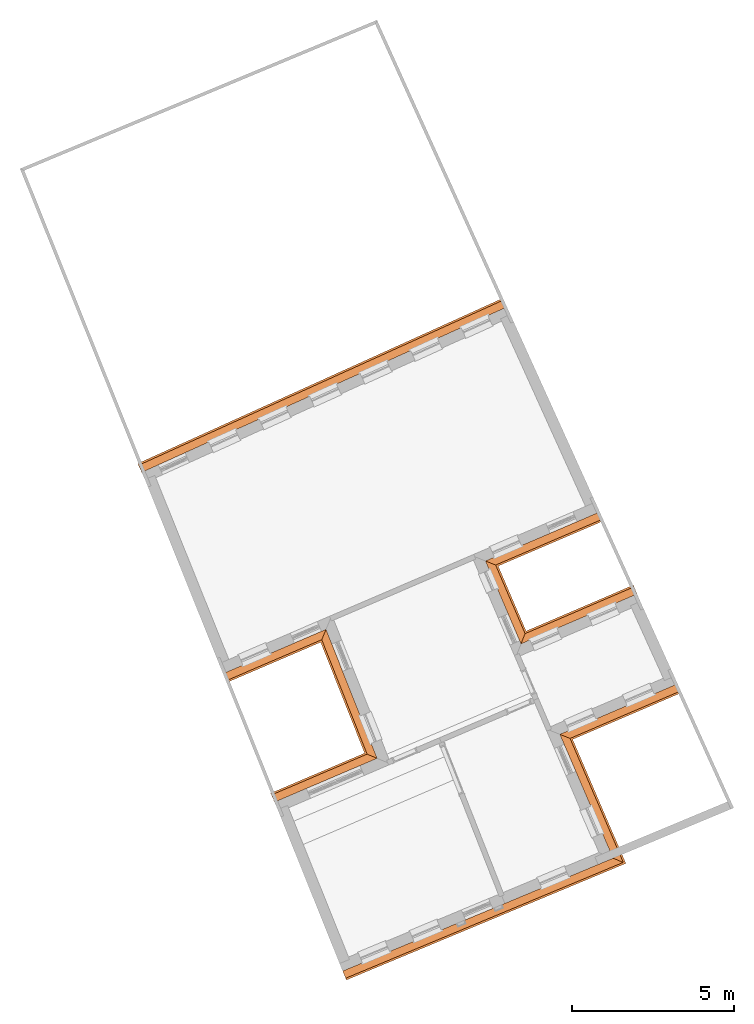
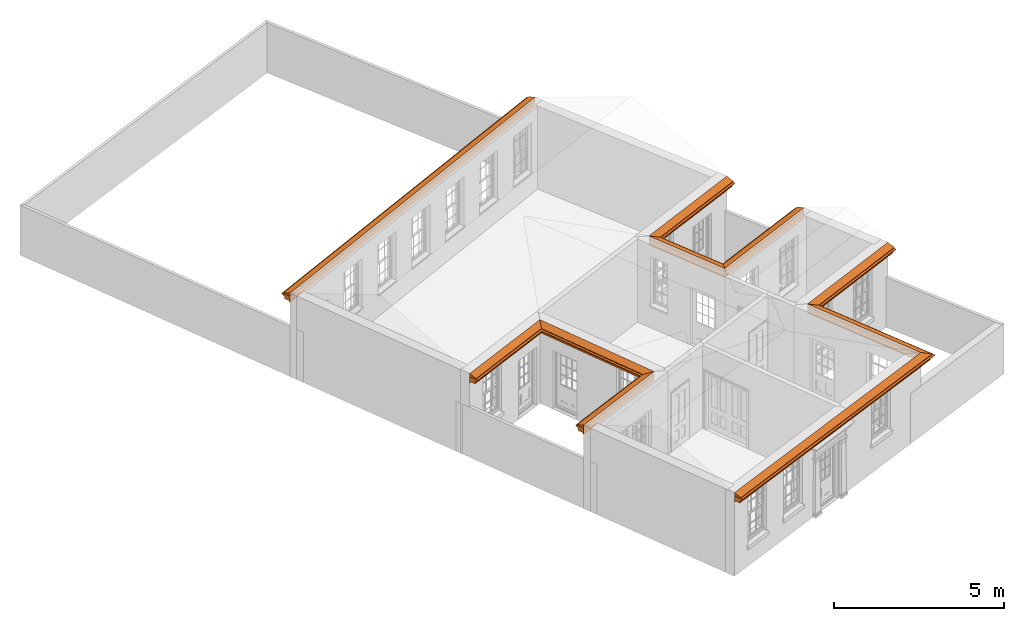
# One storey, part 19 of 19: 8 proxies.
"""IFC2X3 building model written with IfcOpenShell, lengths in metres."""

from ifc_helpers import new_model, entity, si_unit, frame, origin, place, context, subcontext, project, spatial, element, save


model = new_model("IFC2X3")

# Units and contexts
model_context = context("Model", 3, world=origin())
body_context = subcontext(model_context, "Body", "Model", "MODEL_VIEW")
ifc_project = project(units=[si_unit("PLANEANGLEUNIT", "RADIAN"), si_unit("MASSUNIT", "GRAM", prefix="KILO"), si_unit("FORCEUNIT", "NEWTON", prefix="KILO"), si_unit("LENGTHUNIT", "METRE")], contexts=[model_context])

# Site, building, storey
site_placement = place(None, origin())
site = spatial("IfcSite", under=ifc_project, at=site_placement, CompositionType="ELEMENT")
building_placement = place(None, origin())
building = spatial("IfcBuilding", under=site, at=building_placement, Name="Building plot-0", CompositionType="ELEMENT")
storey_placement = place(None, origin())
storey = spatial("IfcBuildingStorey", under=building, at=storey_placement, Name="Floor 0", CompositionType="ELEMENT", Elevation=0.0)

# Proxies
proxy_1_placement = place(storey_placement, frame((0.0, 0.0, 3.0)))
axis2_placement3_d_1 = entity("IfcAxis2Placement3D", entity("IfcCartesianPoint", [0.0, 0.0, 0.0]))
element("IfcBuildingElementProxy", 1, at=proxy_1_placement, inside=storey, Name="eaves", CompositionType="ELEMENT", context=body_context, shape_type="SweptSolid", held_by="IfcProductRepresentation", body=[
    entity("IfcSurfaceCurveSweptAreaSolid", entity("IfcArbitraryClosedProfileDef", "AREA", None, entity("IfcPolyline", [entity("IfcCartesianPoint", [-0.11, 0.25]), entity("IfcCartesianPoint", [-0.33, 0.25]), entity("IfcCartesianPoint", [-0.33, 0.265]), entity("IfcCartesianPoint", [-0.318, 0.268]), entity("IfcCartesianPoint", [-0.309, 0.274]), entity("IfcCartesianPoint", [-0.303, 0.283]), entity("IfcCartesianPoint", [-0.3, 0.295]), entity("IfcCartesianPoint", [-0.285, 0.295]), entity("IfcCartesianPoint", [-0.285, 0.455]), entity("IfcCartesianPoint", [-0.205, 0.455]), entity("IfcCartesianPoint", [-0.205, 0.47]), entity("IfcCartesianPoint", [-0.19, 0.47]), entity("IfcCartesianPoint", [-0.189, 0.483]), entity("IfcCartesianPoint", [-0.186, 0.494]), entity("IfcCartesianPoint", [-0.179, 0.506]), entity("IfcCartesianPoint", [-0.17, 0.514]), entity("IfcCartesianPoint", [-0.16, 0.52]), entity("IfcCartesianPoint", [-0.149, 0.529]), entity("IfcCartesianPoint", [-0.143, 0.539]), entity("IfcCartesianPoint", [-0.14, 0.55]), entity("IfcCartesianPoint", [-0.12, 0.55]), entity("IfcCartesianPoint", [-0.11, 0.48]), entity("IfcCartesianPoint", [-0.11, 0.25])])), axis2_placement3_d_1, entity("IfcPolyline", [entity("IfcCartesianPoint", [21.4677085702817, 40.4618019611669]), entity("IfcCartesianPoint", [10.1981204498091, 35.3580948293064])]), 0.0, 1.0, entity("IfcPlane", axis2_placement3_d_1)),
])
proxy_2_placement = place(storey_placement, frame((0.0, 0.0, 3.0)))
axis2_placement3_d_2 = entity("IfcAxis2Placement3D", entity("IfcCartesianPoint", [0.0, 0.0, 0.0]))
element("IfcBuildingElementProxy", 2, at=proxy_2_placement, inside=storey, Name="eaves", CompositionType="ELEMENT", context=body_context, shape_type="SweptSolid", held_by="IfcProductRepresentation", body=[
    entity("IfcSurfaceCurveSweptAreaSolid", entity("IfcArbitraryClosedProfileDef", "AREA", None, entity("IfcPolyline", [entity("IfcCartesianPoint", [-0.11, 0.25]), entity("IfcCartesianPoint", [-0.11, 0.48]), entity("IfcCartesianPoint", [-0.08, 0.49]), entity("IfcCartesianPoint", [0.0, 0.25]), entity("IfcCartesianPoint", [-0.11, 0.25])])), axis2_placement3_d_2, entity("IfcPolyline", [entity("IfcCartesianPoint", [21.4677085702817, 40.4618019611669]), entity("IfcCartesianPoint", [10.1981204498091, 35.3580948293064])]), 0.0, 1.0, entity("IfcPlane", axis2_placement3_d_2)),
])
proxy_3_placement = place(storey_placement, frame((0.0, 0.0, 3.0)))
axis2_placement3_d_3 = entity("IfcAxis2Placement3D", entity("IfcCartesianPoint", [0.0, 0.0, 0.0]))
element("IfcBuildingElementProxy", 3, at=proxy_3_placement, inside=storey, Name="eaves", CompositionType="ELEMENT", context=body_context, shape_type="SweptSolid", held_by="IfcProductRepresentation", body=[
    entity("IfcSurfaceCurveSweptAreaSolid", entity("IfcArbitraryClosedProfileDef", "AREA", None, entity("IfcPolyline", [entity("IfcCartesianPoint", [-0.11, 0.25]), entity("IfcCartesianPoint", [-0.33, 0.25]), entity("IfcCartesianPoint", [-0.33, 0.265]), entity("IfcCartesianPoint", [-0.318, 0.268]), entity("IfcCartesianPoint", [-0.309, 0.274]), entity("IfcCartesianPoint", [-0.303, 0.283]), entity("IfcCartesianPoint", [-0.3, 0.295]), entity("IfcCartesianPoint", [-0.285, 0.295]), entity("IfcCartesianPoint", [-0.285, 0.455]), entity("IfcCartesianPoint", [-0.205, 0.455]), entity("IfcCartesianPoint", [-0.205, 0.47]), entity("IfcCartesianPoint", [-0.19, 0.47]), entity("IfcCartesianPoint", [-0.189, 0.483]), entity("IfcCartesianPoint", [-0.186, 0.494]), entity("IfcCartesianPoint", [-0.179, 0.506]), entity("IfcCartesianPoint", [-0.17, 0.514]), entity("IfcCartesianPoint", [-0.16, 0.52]), entity("IfcCartesianPoint", [-0.149, 0.529]), entity("IfcCartesianPoint", [-0.143, 0.539]), entity("IfcCartesianPoint", [-0.14, 0.55]), entity("IfcCartesianPoint", [-0.12, 0.55]), entity("IfcCartesianPoint", [-0.11, 0.48]), entity("IfcCartesianPoint", [-0.11, 0.25])])), axis2_placement3_d_3, entity("IfcPolyline", [entity("IfcCartesianPoint", [12.5098741055976, 29.6085621392121]), entity("IfcCartesianPoint", [15.9195076975651, 31.0723375452065]), entity("IfcCartesianPoint", [17.6814146621189, 26.6277936031181]), entity("IfcCartesianPoint", [14.2903609772611, 25.1806408053285])]), 0.0, 1.0, entity("IfcPlane", axis2_placement3_d_3)),
])
proxy_4_placement = place(storey_placement, frame((0.0, 0.0, 3.0)))
axis2_placement3_d_4 = entity("IfcAxis2Placement3D", entity("IfcCartesianPoint", [0.0, 0.0, 0.0]))
element("IfcBuildingElementProxy", 4, at=proxy_4_placement, inside=storey, Name="eaves", CompositionType="ELEMENT", context=body_context, shape_type="SweptSolid", held_by="IfcProductRepresentation", body=[
    entity("IfcSurfaceCurveSweptAreaSolid", entity("IfcArbitraryClosedProfileDef", "AREA", None, entity("IfcPolyline", [entity("IfcCartesianPoint", [-0.11, 0.25]), entity("IfcCartesianPoint", [-0.11, 0.48]), entity("IfcCartesianPoint", [-0.08, 0.49]), entity("IfcCartesianPoint", [0.0, 0.25]), entity("IfcCartesianPoint", [-0.11, 0.25])])), axis2_placement3_d_4, entity("IfcPolyline", [entity("IfcCartesianPoint", [12.5098741055976, 29.6085621392121]), entity("IfcCartesianPoint", [15.9195076975651, 31.0723375452065]), entity("IfcCartesianPoint", [17.6814146621189, 26.6277936031181]), entity("IfcCartesianPoint", [14.2903609772611, 25.1806408053285])]), 0.0, 1.0, entity("IfcPlane", axis2_placement3_d_4)),
])
proxy_5_placement = place(storey_placement, frame((0.0, 0.0, 3.0)))
axis2_placement3_d_5 = entity("IfcAxis2Placement3D", entity("IfcCartesianPoint", [0.0, 0.0, 0.0]))
element("IfcBuildingElementProxy", 5, at=proxy_5_placement, inside=storey, Name="eaves", CompositionType="ELEMENT", context=body_context, shape_type="SweptSolid", held_by="IfcProductRepresentation", body=[
    entity("IfcSurfaceCurveSweptAreaSolid", entity("IfcArbitraryClosedProfileDef", "AREA", None, entity("IfcPolyline", [entity("IfcCartesianPoint", [-0.11, 0.25]), entity("IfcCartesianPoint", [-0.33, 0.25]), entity("IfcCartesianPoint", [-0.33, 0.265]), entity("IfcCartesianPoint", [-0.318, 0.268]), entity("IfcCartesianPoint", [-0.309, 0.274]), entity("IfcCartesianPoint", [-0.303, 0.283]), entity("IfcCartesianPoint", [-0.3, 0.295]), entity("IfcCartesianPoint", [-0.285, 0.295]), entity("IfcCartesianPoint", [-0.285, 0.455]), entity("IfcCartesianPoint", [-0.205, 0.455]), entity("IfcCartesianPoint", [-0.205, 0.47]), entity("IfcCartesianPoint", [-0.19, 0.47]), entity("IfcCartesianPoint", [-0.189, 0.483]), entity("IfcCartesianPoint", [-0.186, 0.494]), entity("IfcCartesianPoint", [-0.179, 0.506]), entity("IfcCartesianPoint", [-0.17, 0.514]), entity("IfcCartesianPoint", [-0.16, 0.52]), entity("IfcCartesianPoint", [-0.149, 0.529]), entity("IfcCartesianPoint", [-0.143, 0.539]), entity("IfcCartesianPoint", [-0.14, 0.55]), entity("IfcCartesianPoint", [-0.12, 0.55]), entity("IfcCartesianPoint", [-0.11, 0.48]), entity("IfcCartesianPoint", [-0.11, 0.25])])), axis2_placement3_d_5, entity("IfcPolyline", [entity("IfcCartesianPoint", [25.4796158495053, 31.6029189208645]), entity("IfcCartesianPoint", [21.6674550050131, 29.9663362390749]), entity("IfcCartesianPoint", [20.3720274852626, 32.983830022078]), entity("IfcCartesianPoint", [24.1246465837847, 34.5948510882189])]), 0.0, 1.0, entity("IfcPlane", axis2_placement3_d_5)),
])
proxy_6_placement = place(storey_placement, frame((0.0, 0.0, 3.0)))
axis2_placement3_d_6 = entity("IfcAxis2Placement3D", entity("IfcCartesianPoint", [0.0, 0.0, 0.0]))
element("IfcBuildingElementProxy", 6, at=proxy_6_placement, inside=storey, Name="eaves", CompositionType="ELEMENT", context=body_context, shape_type="SweptSolid", held_by="IfcProductRepresentation", body=[
    entity("IfcSurfaceCurveSweptAreaSolid", entity("IfcArbitraryClosedProfileDef", "AREA", None, entity("IfcPolyline", [entity("IfcCartesianPoint", [-0.11, 0.25]), entity("IfcCartesianPoint", [-0.11, 0.48]), entity("IfcCartesianPoint", [-0.08, 0.49]), entity("IfcCartesianPoint", [0.0, 0.25]), entity("IfcCartesianPoint", [-0.11, 0.25])])), axis2_placement3_d_6, entity("IfcPolyline", [entity("IfcCartesianPoint", [25.4796158495053, 31.6029189208645]), entity("IfcCartesianPoint", [21.6674550050131, 29.9663362390749]), entity("IfcCartesianPoint", [20.3720274852626, 32.983830022078]), entity("IfcCartesianPoint", [24.1246465837847, 34.5948510882189])]), 0.0, 1.0, entity("IfcPlane", axis2_placement3_d_6)),
])
proxy_7_placement = place(storey_placement, frame((0.0, 0.0, 3.0)))
axis2_placement3_d_7 = entity("IfcAxis2Placement3D", entity("IfcCartesianPoint", [0.0, 0.0, 0.0]))
element("IfcBuildingElementProxy", 7, at=proxy_7_placement, inside=storey, Name="eaves", CompositionType="ELEMENT", context=body_context, shape_type="SweptSolid", held_by="IfcProductRepresentation", body=[
    entity("IfcSurfaceCurveSweptAreaSolid", entity("IfcArbitraryClosedProfileDef", "AREA", None, entity("IfcPolyline", [entity("IfcCartesianPoint", [-0.11, 0.25]), entity("IfcCartesianPoint", [-0.33, 0.25]), entity("IfcCartesianPoint", [-0.33, 0.265]), entity("IfcCartesianPoint", [-0.318, 0.268]), entity("IfcCartesianPoint", [-0.309, 0.274]), entity("IfcCartesianPoint", [-0.303, 0.283]), entity("IfcCartesianPoint", [-0.3, 0.295]), entity("IfcCartesianPoint", [-0.285, 0.295]), entity("IfcCartesianPoint", [-0.285, 0.455]), entity("IfcCartesianPoint", [-0.205, 0.455]), entity("IfcCartesianPoint", [-0.205, 0.47]), entity("IfcCartesianPoint", [-0.19, 0.47]), entity("IfcCartesianPoint", [-0.189, 0.483]), entity("IfcCartesianPoint", [-0.186, 0.494]), entity("IfcCartesianPoint", [-0.179, 0.506]), entity("IfcCartesianPoint", [-0.17, 0.514]), entity("IfcCartesianPoint", [-0.16, 0.52]), entity("IfcCartesianPoint", [-0.149, 0.529]), entity("IfcCartesianPoint", [-0.143, 0.539]), entity("IfcCartesianPoint", [-0.14, 0.55]), entity("IfcCartesianPoint", [-0.12, 0.55]), entity("IfcCartesianPoint", [-0.11, 0.48]), entity("IfcCartesianPoint", [-0.11, 0.25])])), axis2_placement3_d_7, entity("IfcPolyline", [entity("IfcCartesianPoint", [16.2008332385156, 20.4293991315765]), entity("IfcCartesianPoint", [24.309242394874, 23.8127098081217]), entity("IfcCartesianPoint", [22.6688754511049, 27.6336854931373]), entity("IfcCartesianPoint", [26.5270645919712, 29.2900283885672])]), 0.0, 1.0, entity("IfcPlane", axis2_placement3_d_7)),
])
proxy_8_placement = place(storey_placement, frame((0.0, 0.0, 3.0)))
axis2_placement3_d_8 = entity("IfcAxis2Placement3D", entity("IfcCartesianPoint", [0.0, 0.0, 0.0]))
element("IfcBuildingElementProxy", 8, at=proxy_8_placement, inside=storey, Name="eaves", CompositionType="ELEMENT", context=body_context, shape_type="SweptSolid", held_by="IfcProductRepresentation", body=[
    entity("IfcSurfaceCurveSweptAreaSolid", entity("IfcArbitraryClosedProfileDef", "AREA", None, entity("IfcPolyline", [entity("IfcCartesianPoint", [-0.11, 0.25]), entity("IfcCartesianPoint", [-0.11, 0.48]), entity("IfcCartesianPoint", [-0.08, 0.49]), entity("IfcCartesianPoint", [0.0, 0.25]), entity("IfcCartesianPoint", [-0.11, 0.25])])), axis2_placement3_d_8, entity("IfcPolyline", [entity("IfcCartesianPoint", [16.2008332385156, 20.4293991315765]), entity("IfcCartesianPoint", [24.309242394874, 23.8127098081217]), entity("IfcCartesianPoint", [22.6688754511049, 27.6336854931373]), entity("IfcCartesianPoint", [26.5270645919712, 29.2900283885672])]), 0.0, 1.0, entity("IfcPlane", axis2_placement3_d_8)),
])

save(model, "model.ifc")
